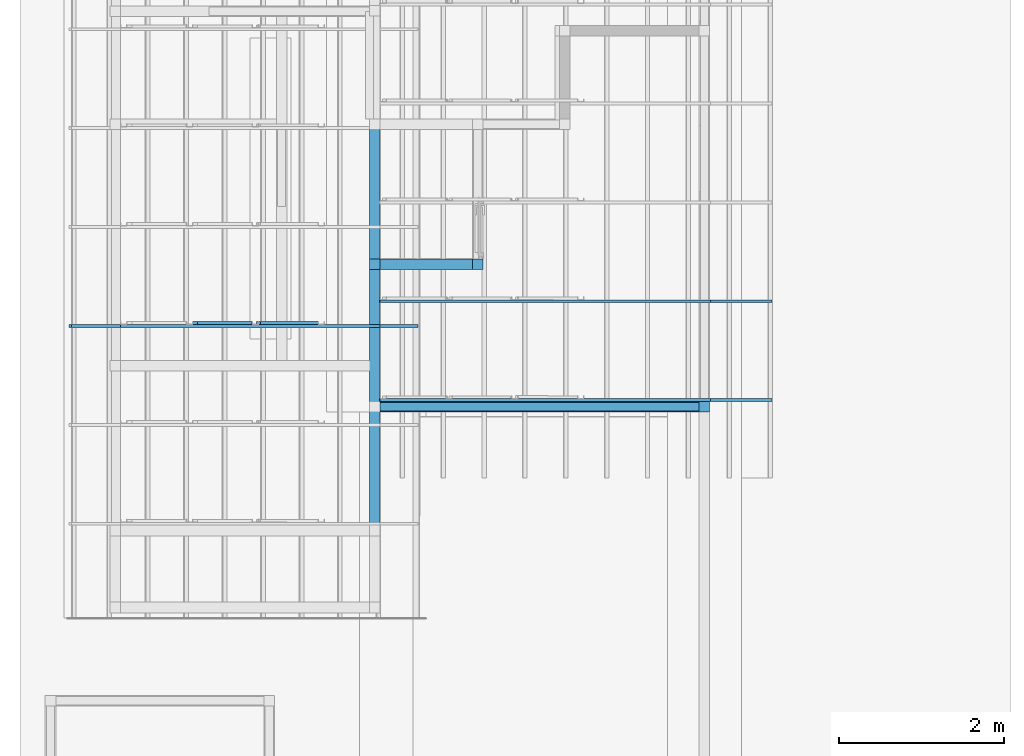
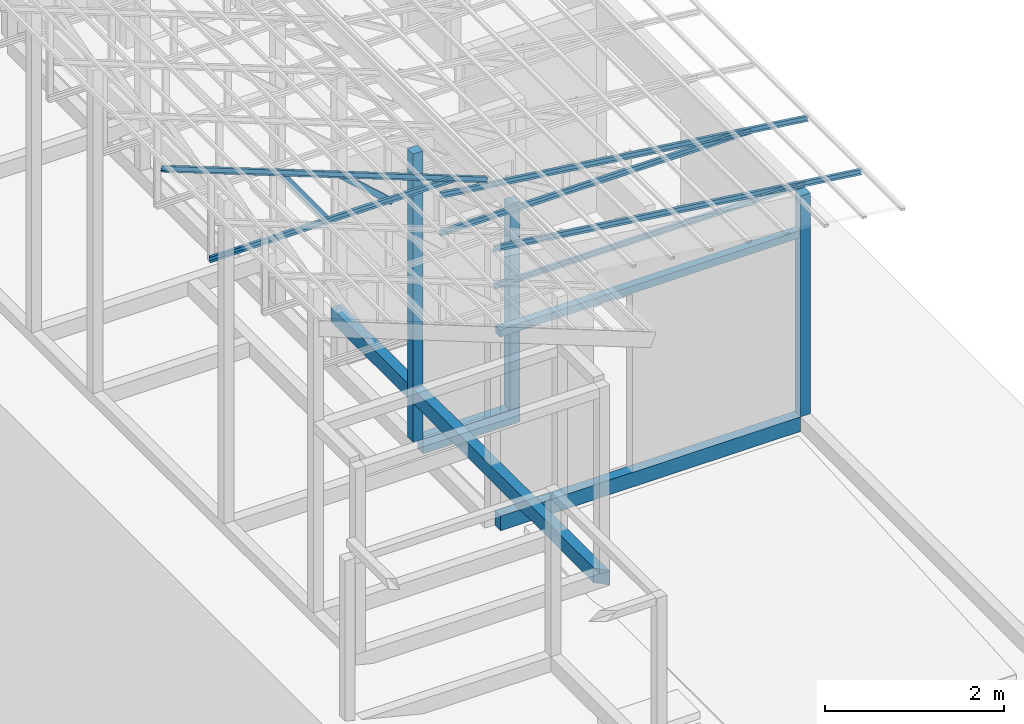
# One storey, part 5 of 22: 8 members, 7 beams, 2 elements without a shape of their own.
"""IFC4 building model written with IfcOpenShell, lengths in millimetres."""

from ifc_helpers import new_model, entity, si_unit, converted_unit, frame, origin_with_axes, origin_2d_with_axis, place, context, subcontext, project, spatial, indexed_curve, rectangle, c_section, outline, extrude, clip, halfspace, material, material_profile, profile_set, profile_usage, type_object, element, aggregate, save


model = new_model("IFC4")

# Units and contexts
model_context = context("Model", 3, precision=1e-05, world=origin_with_axes())
plan_context = context("Plan", 2, precision=1e-05, world=origin_2d_with_axis())
body_context = subcontext(model_context, "Body", "Model", "MODEL_VIEW")
ifc_project = project(units=[si_unit("VOLUMEUNIT", "CUBIC_METRE"), si_unit("LENGTHUNIT", "METRE", prefix="MILLI"), si_unit("AREAUNIT", "SQUARE_METRE"), converted_unit("PLANEANGLEUNIT", "degree", entity("IfcReal", 0.0174532925199433), si_unit("PLANEANGLEUNIT", "RADIAN"), dimensions=[0, 0, 0, 0, 0, 0, 0])], contexts=[model_context, plan_context])

# Site, building, storey
site_placement = place(None, origin_with_axes())
site = spatial("IfcSite", under=ifc_project, at=site_placement)
building_placement = place(site_placement, origin_with_axes())
building = spatial("IfcBuilding", under=site, at=building_placement, Name="2")
storey_placement = place(building_placement, frame((0.0, 0.0, 200.000002980232), z_axis=(0.0, 0.0, 1.0), x_axis=(1.0, 0.0, 0.0)))
storey = spatial("IfcBuildingStorey", under=building, at=storey_placement)

# Beams
ifc_material_1 = material(Name="Concrete")
ifc_material_profile_1 = material_profile(ifc_material_1, outline(indexed_curve([(-65.0, 99.9999923706055), (65.0, 99.9999923706055), (65.0, -99.9999923706055), (-65.0, -99.9999923706055), (-65.0, 99.9999923706055)])))
ifc_profile_set_1 = profile_set([ifc_material_profile_1])
ifc_profile_usage_1 = profile_usage(ifc_profile_set_1, cardinal=2)
beam_type_1 = type_object("IfcBeamType", PredefinedType="BEAM", material=ifc_profile_set_1)
beam_1_placement = place(storey_placement, frame((-3934.99803543091, 8230.00144958496, -200.000609421465), z_axis=(0.999999999999968, 1.62920670732087e-07, 1.94707183709391e-07), x_axis=(-1.62920684942944e-07, 0.999999999999985, 5.9604630564535e-08)))
element("IfcBeam", 1, at=beam_1_placement, inside=storey, type_object=beam_type_1, material=ifc_profile_usage_1, Name="Beam", PredefinedType="BEAM", context=body_context, shape_type="Clipping", body=[
    clip(extrude(outline(indexed_curve([(-65.0, 99.9999923706055), (65.0, 99.9999923706055), (65.0, -99.9999923706055), (-65.0, -99.9999923706055), (-65.0, 99.9999923706055)])), frame((0.0, 100.0, 0.0), z_axis=(0.0, 0.0, 1.0), x_axis=(1.0, 0.0, 0.0)), (0.0, 0.0, 1.0), 1250.00309943771), halfspace(frame((-65.0010481476784, 0.0010883327377087, 1250.00298023224), z_axis=(0.707109272480011, -1.99495289621154e-07, 0.707104325294495), x_axis=(-2.82127950212654e-07, -0.99999999999996, 0.0)), False)),
])
ifc_profile_usage_2 = profile_usage(ifc_profile_set_1, cardinal=2)
beam_2_placement = place(storey_placement, frame((-3934.99779701233, 6500.00047683716, -200.000648660875), z_axis=(0.999999999999754, -4.33125620702306e-07, 5.52335052361605e-07), x_axis=(4.33125762810904e-07, 0.99999999999987, -2.68220901489223e-07)))
element("IfcBeam", 2, at=beam_2_placement, inside=storey, type_object=beam_type_1, material=ifc_profile_usage_2, Name="Beam", PredefinedType="BEAM", context=body_context, shape_type="SweptSolid", body=[
    extrude(outline(indexed_curve([(-65.0, 99.9999923706055), (65.0, 99.9999923706055), (65.0, -99.9999923706055), (-65.0, -99.9999923706055), (-65.0, 99.9999923706055)])), frame((0.0, 100.0, 0.0), z_axis=(0.0, 0.0, 1.0), x_axis=(1.0, 0.0, 0.0)), (0.0, 0.0, 1.0), 3869.99841123354),
])
ifc_profile_usage_3 = profile_usage(ifc_profile_set_1, cardinal=3)
beam_3_placement = place(storey_placement, frame((-3934.9958896637, 4000.00381469727, 535.00346839428), z_axis=(3.89414367418746e-07, 0.999999999999875, 3.13916473260139e-07), x_axis=(-0.999999999999924, 3.89414367418765e-07, -7.40532613008271e-09)))
element("IfcBeam", 3, at=beam_3_placement, inside=storey, type_object=beam_type_1, material=ifc_profile_usage_3, Name="Beam", PredefinedType="BEAM", context=body_context, shape_type="Clipping", body=[
    clip(extrude(outline(indexed_curve([(-65.0, 99.9999923706055), (65.0, 99.9999923706055), (65.0, -99.9999923706055), (-65.0, -99.9999923706055), (-65.0, 99.9999923706055)])), frame((65.0000076293945, 100.0, 0.0), z_axis=(0.0, 0.0, 1.0), x_axis=(1.0, 0.0, 0.0)), (0.0, 0.0, 1.0), 5994.99716407971), halfspace(frame((-0.000349689653376117, -735.003967285156, -0.000101832534710411), z_axis=(0.707106471061707, -1.63350975412868e-07, -0.707107067108154), x_axis=(-5.4492971912623e-07, -1.0, -3.13916245886503e-07)), False)),
])
ifc_material_profile_2 = material_profile(ifc_material_1, rectangle(XDim=130.000015258789, YDim=130.000015258789, kind="CURVE"))
ifc_profile_set_2 = profile_set([ifc_material_profile_2])
ifc_profile_usage_4 = profile_usage(ifc_profile_set_2, cardinal=5)
beam_type_2 = type_object("IfcBeamType", PredefinedType="BEAM", material=ifc_profile_set_2)
beam_4_placement = place(storey_placement, frame((-2749.99499320984, 8230.00144958496, -0.000312924384848756), z_axis=(0.0, 0.0, 1.0), x_axis=(1.0, 0.0, 0.0)))
element("IfcBeam", 4, at=beam_4_placement, inside=storey, type_object=beam_type_2, material=ifc_profile_usage_4, Name="Column", PredefinedType="BEAM", context=body_context, shape_type="SweptSolid", body=[
    extrude(rectangle(XDim=130.000015258789, YDim=130.000015258789, kind="CURVE"), origin_with_axes(), (0.0, 0.0, 1.0), 2811.24349712944),
])
ifc_profile_usage_5 = profile_usage(ifc_profile_set_2, cardinal=2)
beam_5_placement = place(storey_placement, frame((0.000424683094024658, 6434.99898910522, 0.00150501728057861), z_axis=(0.0, 0.0, 1.0), x_axis=(1.0, 0.0, 0.0)))
element("IfcBeam", 5, at=beam_5_placement, inside=storey, type_object=beam_type_2, material=ifc_profile_usage_5, Name="Column", PredefinedType="BEAM", context=body_context, shape_type="SweptSolid", body=[
    extrude(rectangle(XDim=130.000015258789, YDim=130.000015258789, kind="CURVE"), frame((0.0, 65.0000076293945, 0.0), z_axis=(0.0, 0.0, 1.0), x_axis=(1.0, 0.0, 0.0)), (0.0, 0.0, 1.0), 3010.00928047245),
])
ifc_profile_usage_6 = profile_usage(ifc_profile_set_2, cardinal=5)
beam_6_placement = place(storey_placement, frame((-3999.99690055847, 8230.00144958496, -0.000312924385070801), z_axis=(0.0, 0.0, 1.0), x_axis=(1.0, 0.0, 0.0)))
element("IfcBeam", 6, at=beam_6_placement, inside=storey, type_object=beam_type_2, material=ifc_profile_usage_6, Name="Column", PredefinedType="BEAM", context=body_context, shape_type="SweptSolid", body=[
    extrude(rectangle(XDim=130.000015258789, YDim=130.000015258789, kind="CURVE"), origin_with_axes(), (0.0, 0.0, 1.0), 3934.94938179236),
])

# Assembly, members
assembly_1_placement = place(storey_placement, frame((-1561.45393848419, 6600.0657081604, 3019.63977515697), z_axis=(0.0, 0.0, 1.0), x_axis=(1.0, 0.0, 0.0)))
assembly_1 = element("IfcElementAssembly", 7, at=assembly_1_placement, inside=storey, Name="K1")
ifc_material_2 = material(Name="STEEL")
ifc_material_profile_3 = material_profile(ifc_material_2, c_section(Depth=75.0, Width=35.0, WallThickness=1.0, Girth=1.0, kind="CURVE"))
ifc_profile_set_3 = profile_set([ifc_material_profile_3])
ifc_profile_usage_7 = profile_usage(ifc_profile_set_3, cardinal=9)
member_type = type_object("IfcMemberType", Name="C75", PredefinedType="CHORD", material=ifc_profile_set_3)
member_1_placement = place(assembly_1_placement, frame((1634.4433426857, -1.06668472290039, 64.9838447570801), z_axis=(-0.999999999999996, -7.54978941586157e-08, -4.37113882867378e-08), x_axis=(7.54979012640425e-08, -0.999999999999989, -1.2785038450147e-07)))
member_1 = element("IfcMember", 8, at=member_1_placement, type_object=member_type, material=ifc_profile_usage_7, Name="Member", context=body_context, shape_type="SweptSolid", body=[
    extrude(c_section(Depth=75.0, Width=35.0, WallThickness=1.0, Girth=1.0, kind="CURVE"), frame((17.5, -37.5, 0.0), z_axis=(0.0, 0.0, 1.0), x_axis=(1.0, 0.0, 0.0)), (0.0, 0.0, 1.0), 4007.95455591631),
])
ifc_profile_usage_8 = profile_usage(ifc_profile_set_3, cardinal=9)
member_2_placement = place(assembly_1_placement, frame((2381.98524713516, -1.06668472290039, -28.5120010375977), z_axis=(-0.991864132670109, -9.11591360127481e-08, 0.127300991050989), x_axis=(7.54979012640425e-08, -0.999999999999989, -1.2785038450147e-07)))
member_2 = element("IfcMember", 9, at=member_2_placement, type_object=member_type, material=ifc_profile_usage_8, Name="Member", context=body_context, shape_type="SweptSolid", body=[
    extrude(c_section(Depth=75.0, Width=35.0, WallThickness=1.0, Girth=1.0, kind="CURVE"), frame((17.5, -37.5, 0.0), z_axis=(0.0, 0.0, 1.0), x_axis=(1.0, 0.0, 0.0)), (0.0, 0.0, 1.0), 4790.46084290085),
])
ifc_profile_usage_9 = profile_usage(ifc_profile_set_3, cardinal=9)
member_3_placement = place(assembly_1_placement, frame((1634.4433426857, 1198.93312454224, 64.9838447570801), z_axis=(-0.999999999999996, -7.54978941586157e-08, -4.37113882867378e-08), x_axis=(7.54979012640425e-08, -0.999999999999989, -1.2785038450147e-07)))
member_3 = element("IfcMember", 10, at=member_3_placement, type_object=member_type, material=ifc_profile_usage_9, Name="Member", context=body_context, shape_type="SweptSolid", body=[
    extrude(c_section(Depth=75.0, Width=35.0, WallThickness=1.0, Girth=1.0, kind="CURVE"), frame((17.5, -37.5, 0.0), z_axis=(0.0, 0.0, 1.0), x_axis=(1.0, 0.0, 0.0)), (0.0, 0.0, 1.0), 4007.95455591631),
])
ifc_profile_usage_10 = profile_usage(ifc_profile_set_3, cardinal=9)
member_4_placement = place(assembly_1_placement, frame((2381.98524713516, 1198.93312454224, -28.5120010375977), z_axis=(-0.991864132670109, -9.11591360127481e-08, 0.127300991050989), x_axis=(7.54979012640425e-08, -0.999999999999989, -1.2785038450147e-07)))
member_4 = element("IfcMember", 11, at=member_4_placement, type_object=member_type, material=ifc_profile_usage_10, Name="Member", context=body_context, shape_type="SweptSolid", body=[
    extrude(c_section(Depth=75.0, Width=35.0, WallThickness=1.0, Girth=1.0, kind="CURVE"), frame((17.5, -37.5, 0.0), z_axis=(0.0, 0.0, 1.0), x_axis=(1.0, 0.0, 0.0)), (0.0, 0.0, 1.0), 4790.46084290085),
])
aggregate(assembly_1, [member_1, member_2, member_3, member_4])

assembly_2_placement = place(storey_placement, frame((-3938.51041793823, 5099.00283813477, 3935.3459328413), z_axis=(0.0, 0.0, 1.0), x_axis=(1.0, 0.0, 0.0)))
assembly_2 = element("IfcElementAssembly", 12, at=assembly_2_placement, inside=storey, Name="2")
ifc_profile_usage_11 = profile_usage(ifc_profile_set_3, cardinal=1)
member_5_placement = place(assembly_2_placement, frame((3.51285934448242, 2364.99977111816, -1.35517120361328), z_axis=(-0.999999999999812, -4.33125762810878e-07, 4.33125762810878e-07), x_axis=(4.33125762810919e-07, -0.999999999999906, -1.13742348872837e-13)))
member_5 = element("IfcMember", 13, at=member_5_placement, type_object=member_type, material=ifc_profile_usage_11, Name="Member", context=body_context, shape_type="SweptSolid", body=[
    extrude(c_section(Depth=75.0, Width=35.0, WallThickness=1.0, Girth=1.0, kind="CURVE"), frame((-17.5, 37.5, 0.0), z_axis=(0.0, 0.0, 1.0), x_axis=(1.0, 0.0, 0.0)), (0.0, 0.0, 1.0), 3150.02386296032),
])
ifc_profile_usage_12 = profile_usage(ifc_profile_set_3, cardinal=1)
member_6_placement = place(assembly_2_placement, frame((438.234329223633, 2365.00072479248, -169.034004211426), z_axis=(-0.933001152035968, -8.32115964913738e-07, 0.359873380925658), x_axis=(9.09962921013707e-07, -0.999999999999585, 4.6906695416718e-08)))
member_6 = element("IfcMember", 14, at=member_6_placement, type_object=member_type, material=ifc_profile_usage_12, Name="Member", context=body_context, shape_type="SweptSolid", body=[
    extrude(c_section(Depth=75.0, Width=35.0, WallThickness=1.0, Girth=1.0, kind="CURVE"), frame((-17.5, 37.5, 0.0), z_axis=(0.0, 0.0, 1.0), x_axis=(1.0, 0.0, 0.0)), (0.0, 0.0, 1.0), 4510.0754953159),
])
ifc_profile_usage_13 = profile_usage(ifc_profile_set_3, cardinal=7)
member_7_placement = place(assembly_2_placement, frame((-1445.26290893555, 2435.96076965332, 624.074935913086), z_axis=(0.745142107017777, -0.00102660805644996, -0.66690493057482), x_axis=(0.00137753843534741, 0.999999051193456, -2.17762747561669e-07)))
member_7 = element("IfcMember", 15, at=member_7_placement, type_object=member_type, material=ifc_profile_usage_13, Name="Member", context=body_context, shape_type="SweptSolid", body=[
    extrude(c_section(Depth=75.0, Width=35.0, WallThickness=1.0, Girth=1.0, kind="CURVE"), frame((-17.5, -37.5, 0.0), z_axis=(0.0, 0.0, 1.0), x_axis=(1.0, 0.0, 0.0)), (0.0, 0.0, 1.0), 937.808496265298),
])
ifc_profile_usage_14 = profile_usage(ifc_profile_set_3, cardinal=3)
member_8_placement = place(assembly_2_placement, frame((-2271.51107788086, 2399.99961853027, 894.618034362793), z_axis=(0.578723368640778, -7.49756619914683e-07, -0.815523919078103), x_axis=(1.02917226740772e-06, 0.999999999999453, -1.89020340712783e-07)))
member_8 = element("IfcMember", 16, at=member_8_placement, type_object=member_type, material=ifc_profile_usage_14, Name="Member", context=body_context, shape_type="SweptSolid", body=[
    extrude(c_section(Depth=75.0, Width=35.0, WallThickness=1.0, Girth=1.0, kind="CURVE"), frame((17.5, 37.5, 0.0), z_axis=(0.0, 0.0, 1.0), x_axis=(1.0, 0.0, 0.0)), (0.0, 0.0, 1.0), 1142.30360336039),
])
aggregate(assembly_2, [member_5, member_6, member_7, member_8])

# Beam
ifc_material_profile_4 = material_profile(ifc_material_1, rectangle(XDim=100.0, YDim=100.0))
ifc_profile_set_4 = profile_set([ifc_material_profile_4])
ifc_profile_usage_15 = profile_usage(ifc_profile_set_4, cardinal=2)
beam_type_3 = type_object("IfcBeamType", PredefinedType="BEAM", material=ifc_profile_set_4)
beam_7_placement = place(storey_placement, frame((-3934.99779701233, 6500.00047683716, 2429.99939620495), z_axis=(0.999999999999754, -4.33125620702306e-07, 5.52335052361605e-07), x_axis=(4.33125762810904e-07, 0.99999999999987, -2.68220901489223e-07)))
element("IfcBeam", 17, at=beam_7_placement, inside=storey, type_object=beam_type_3, material=ifc_profile_usage_15, Name="Beam", PredefinedType="BEAM", context=body_context, shape_type="SweptSolid", body=[
    extrude(rectangle(XDim=100.0, YDim=100.0), frame((0.0, 50.0, 0.0), z_axis=(0.0, 0.0, 1.0), x_axis=(1.0, 0.0, 0.0)), (0.0, 0.0, 1.0), 3869.99841123354),
])

save(model, "model.ifc")
